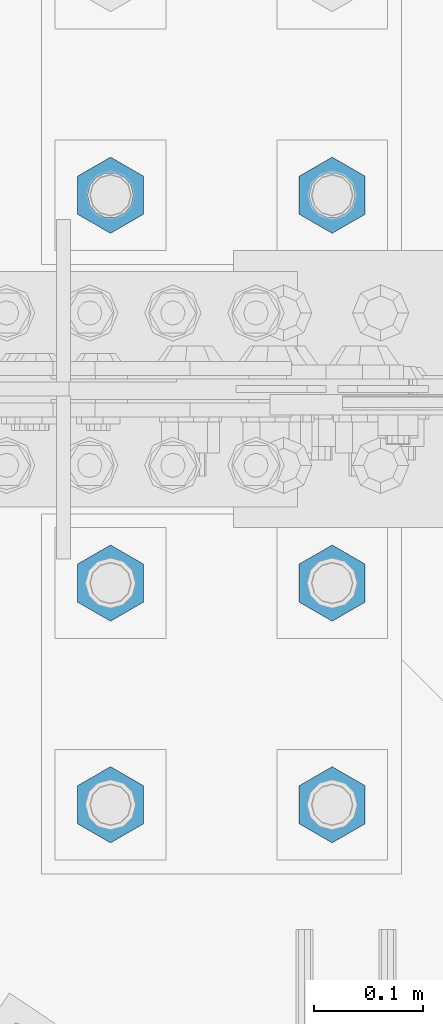
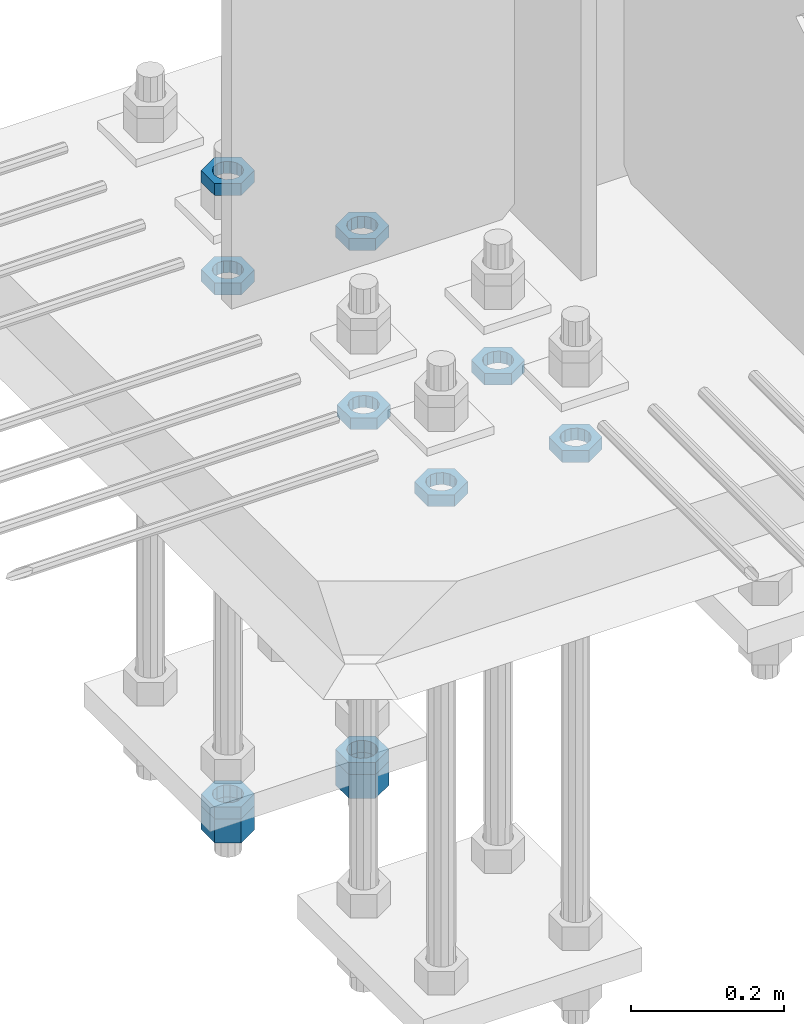
# One storey, part 2961 of 3843: 11 beams, 1 element without a shape of its own.
"""IFC2X3 building model written with IfcOpenShell, lengths in millimetres."""

from ifc_helpers import new_model, si_unit, frame, origin_with_axes, place, context, subcontext, project, spatial, faceted_brep, material, type_object, element, aggregate, save


model = new_model("IFC2X3")

# Units and contexts
model_context = context("Model", 3, precision=1e-05, world=origin_with_axes())
body_context = subcontext(model_context, "Body", "Model", "MODEL_VIEW")
ifc_project = project(units=[si_unit("LENGTHUNIT", "METRE", prefix="MILLI"), si_unit("AREAUNIT", "SQUARE_METRE"), si_unit("VOLUMEUNIT", "CUBIC_METRE"), si_unit("MASSUNIT", "GRAM", prefix="KILO"), si_unit("TIMEUNIT", "SECOND"), si_unit("PLANEANGLEUNIT", "RADIAN"), si_unit("SOLIDANGLEUNIT", "STERADIAN"), si_unit("THERMODYNAMICTEMPERATUREUNIT", "DEGREE_CELSIUS"), si_unit("LUMINOUSINTENSITYUNIT", "LUMEN")], contexts=[model_context])

# Site, building, storey
site_placement = place(None, origin_with_axes())
site = spatial("IfcSite", under=ifc_project, at=site_placement, CompositionType="ELEMENT")
building_placement = place(site_placement, origin_with_axes())
building = spatial("IfcBuilding", under=site, at=building_placement, Name="Undefined", CompositionType="ELEMENT")
storey_placement = place(building_placement, origin_with_axes())
storey = spatial("IfcBuildingStorey", under=building, at=storey_placement, Name="Undefined", CompositionType="ELEMENT", Elevation=0.0)

# Assembly, beams
assembly_placement = place(storey_placement, origin_with_axes())
assembly = element("IfcElementAssembly", 1, at=assembly_placement, inside=storey, Name="TEMPLATE", AssemblyPlace="NOTDEFINED", PredefinedType="RIGID_FRAME")
ifc_material = material(Name="STEEL/A572-50")
beam_type_1 = type_object("IfcBeamType", Name="1-1/2_HEAVY_HEX_NUT", PredefinedType="NOTDEFINED")
beam_1_placement = place(assembly_placement, frame((85140.8, 104736.9, 28746.45), z_axis=(-1.0, 0.0, 0.0), x_axis=(0.0, 0.0, -1.0)))
beam_1 = element("IfcBeam", 2, at=beam_1_placement, type_object=beam_type_1, material=ifc_material, Name="NUT", ObjectType="1-1/2_HEAVY_HEX_NUT", context=body_context, shape_type="Brep", body=[
    faceted_brep([(0.0, -34.9199981689453, 0.0), (0.0, -17.4599990844727, -30.25), (38.0999999999985, -17.4599990844727, -30.25), (38.0999999999985, -34.9199981689453, 0.0), (0.0, 17.4599990844727, -30.25), (38.0999999999985, 17.4599990844727, -30.25), (0.0, 34.9199981689453, 0.0), (38.0999999999985, 34.9199981689453, 0.0), (0.0, 17.4599990844727, 30.25), (38.0999999999985, 17.4599990844727, 30.25), (0.0, -17.4599990844727, 30.25), (38.0999999999985, -17.4599990844727, 30.25), (0.0, 0.0, 20.6399993896484), (0.0, 8.9553601105581, 18.5959968835959), (38.0999999999985, 8.9553601105581, 18.5959968835959), (38.0999999999985, 0.0, 20.6399993896484), (0.0, 16.1370013209525, 12.8688291298167), (38.0999999999985, 16.1370013209525, 12.8688291298167), (0.0, 20.1225115123816, 4.59283194104501), (38.0999999999985, 20.1225115123816, 4.59283194104501), (0.0, 20.1225115123816, -4.59283194104501), (38.0999999999985, 20.1225115123816, -4.59283194104501), (0.0, 16.1370013209525, -12.8688291298167), (38.0999999999985, 16.1370013209525, -12.8688291298167), (0.0, 8.9553601105581, -18.5959968835959), (38.0999999999985, 8.9553601105581, -18.5959968835959), (0.0, 0.0, -20.6399993896484), (38.0999999999985, 0.0, -20.6399993896484), (0.0, -8.9553601105581, -18.5959968835959), (38.0999999999985, -8.9553601105581, -18.5959968835959), (0.0, -16.1370013209525, -12.8688291298167), (38.0999999999985, -16.1370013209525, -12.8688291298167), (0.0, -20.1225115123816, -4.59283194104501), (38.0999999999985, -20.1225115123816, -4.59283194104501), (0.0, -20.1225115123816, 4.59283194104501), (38.0999999999985, -20.1225115123816, 4.59283194104501), (0.0, -16.1370013209525, 12.8688291298167), (38.0999999999985, -16.1370013209525, 12.8688291298167), (0.0, -8.9553601105581, 18.5959968835959), (38.0999999999985, -8.9553601105581, 18.5959968835959)], [[[0, 1, 2, 3]], [[1, 4, 5, 2]], [[4, 6, 7, 5]], [[6, 8, 9, 7]], [[8, 10, 11, 9]], [[10, 0, 3, 11]], [[12, 13, 14, 15]], [[13, 16, 17, 14]], [[16, 18, 19, 17]], [[18, 20, 21, 19]], [[20, 22, 23, 21]], [[22, 24, 25, 23]], [[24, 26, 27, 25]], [[26, 28, 29, 27]], [[28, 30, 31, 29]], [[30, 32, 33, 31]], [[32, 34, 35, 33]], [[34, 36, 37, 35]], [[36, 38, 39, 37]], [[38, 12, 15, 39]], [[5, 7, 9, 11, 3, 2], [17, 19, 21, 23, 25, 27, 29, 31, 33, 35, 37, 39, 15, 14]], [[10, 8, 6, 4, 1, 0], [38, 36, 34, 32, 30, 28, 26, 24, 22, 20, 18, 16, 13, 12]]]),
])
beam_2_placement = place(assembly_placement, frame((85344.0, 104736.9, 28746.45), z_axis=(-1.0, 0.0, 0.0), x_axis=(0.0, 0.0, -1.0)))
beam_2 = element("IfcBeam", 3, at=beam_2_placement, type_object=beam_type_1, material=ifc_material, Name="NUT", ObjectType="1-1/2_HEAVY_HEX_NUT", context=body_context, shape_type="Brep", body=[
    faceted_brep([(0.0, -34.9199981689453, 0.0), (0.0, -17.4599990844727, -30.25), (38.0999999999985, -17.4599990844727, -30.25), (38.0999999999985, -34.9199981689453, 0.0), (0.0, 17.4599990844727, -30.25), (38.0999999999985, 17.4599990844727, -30.25), (0.0, 34.9199981689453, 0.0), (38.0999999999985, 34.9199981689453, 0.0), (0.0, 17.4599990844727, 30.25), (38.0999999999985, 17.4599990844727, 30.25), (0.0, -17.4599990844727, 30.25), (38.0999999999985, -17.4599990844727, 30.25), (0.0, 0.0, 20.6399993896484), (0.0, 8.9553601105581, 18.5959968835959), (38.0999999999985, 8.9553601105581, 18.5959968835959), (38.0999999999985, 0.0, 20.6399993896484), (0.0, 16.1370013209525, 12.8688291298167), (38.0999999999985, 16.1370013209525, 12.8688291298167), (0.0, 20.1225115123816, 4.59283194104501), (38.0999999999985, 20.1225115123816, 4.59283194104501), (0.0, 20.1225115123816, -4.59283194104501), (38.0999999999985, 20.1225115123816, -4.59283194104501), (0.0, 16.1370013209525, -12.8688291298167), (38.0999999999985, 16.1370013209525, -12.8688291298167), (0.0, 8.9553601105581, -18.5959968835959), (38.0999999999985, 8.9553601105581, -18.5959968835959), (0.0, 0.0, -20.6399993896484), (38.0999999999985, 0.0, -20.6399993896484), (0.0, -8.9553601105581, -18.5959968835959), (38.0999999999985, -8.9553601105581, -18.5959968835959), (0.0, -16.1370013209525, -12.8688291298167), (38.0999999999985, -16.1370013209525, -12.8688291298167), (0.0, -20.1225115123816, -4.59283194104501), (38.0999999999985, -20.1225115123816, -4.59283194104501), (0.0, -20.1225115123816, 4.59283194104501), (38.0999999999985, -20.1225115123816, 4.59283194104501), (0.0, -16.1370013209525, 12.8688291298167), (38.0999999999985, -16.1370013209525, 12.8688291298167), (0.0, -8.9553601105581, 18.5959968835959), (38.0999999999985, -8.9553601105581, 18.5959968835959)], [[[0, 1, 2, 3]], [[1, 4, 5, 2]], [[4, 6, 7, 5]], [[6, 8, 9, 7]], [[8, 10, 11, 9]], [[10, 0, 3, 11]], [[12, 13, 14, 15]], [[13, 16, 17, 14]], [[16, 18, 19, 17]], [[18, 20, 21, 19]], [[20, 22, 23, 21]], [[22, 24, 25, 23]], [[24, 26, 27, 25]], [[26, 28, 29, 27]], [[28, 30, 31, 29]], [[30, 32, 33, 31]], [[32, 34, 35, 33]], [[34, 36, 37, 35]], [[36, 38, 39, 37]], [[38, 12, 15, 39]], [[5, 7, 9, 11, 3, 2], [17, 19, 21, 23, 25, 27, 29, 31, 33, 35, 37, 39, 15, 14]], [[10, 8, 6, 4, 1, 0], [38, 36, 34, 32, 30, 28, 26, 24, 22, 20, 18, 16, 13, 12]]]),
])
beam_type_2 = type_object("IfcBeamType", Name="1-1/2_HALF_NUT", PredefinedType="NOTDEFINED")
beam_3_placement = place(assembly_placement, frame((85140.8, 104736.9, 29603.7), z_axis=(-1.0, 0.0, 0.0), x_axis=(0.0, 0.0, -1.0)))
beam_3 = element("IfcBeam", 4, at=beam_3_placement, type_object=beam_type_2, material=ifc_material, Name="NUT", ObjectType="1-1/2_HALF_NUT", context=body_context, shape_type="Brep", body=[
    faceted_brep([(0.0, -34.9199981689453, 0.0), (0.0, -17.4599990844727, -30.25), (19.0500000000029, -17.4599990844727, -30.25), (19.0500000000029, -34.9199981689453, 0.0), (0.0, 17.4599990844727, -30.25), (19.0500000000029, 17.4599990844727, -30.25), (0.0, 34.9199981689453, 0.0), (19.0500000000029, 34.9199981689453, 0.0), (0.0, 17.4599990844727, 30.25), (19.0500000000029, 17.4599990844727, 30.25), (0.0, -17.4599990844727, 30.25), (19.0500000000029, -17.4599990844727, 30.25), (0.0, 0.0, 20.6399993896484), (0.0, 8.9553601105581, 18.5959968835959), (19.0500000000029, 8.95536011056538, 18.5959968835959), (19.0500000000029, 0.0, 20.6399993896484), (0.0, 16.1370013209525, 12.8688291298167), (19.0500000000029, 16.1370013209489, 12.8688291298167), (0.0, 20.1225115123816, 4.59283194104501), (19.0500000000029, 20.1225115123852, 4.59283194104501), (0.0, 20.1225115123816, -4.59283194104501), (19.0500000000029, 20.1225115123852, -4.59283194104501), (0.0, 16.1370013209525, -12.8688291298167), (19.0500000000029, 16.1370013209489, -12.8688291298167), (0.0, 8.9553601105581, -18.5959968835959), (19.0500000000029, 8.95536011056538, -18.5959968835959), (0.0, 0.0, -20.6399993896484), (19.0500000000029, 0.0, -20.6399993896484), (0.0, -8.9553601105581, -18.5959968835959), (19.0500000000029, -8.95536011056538, -18.5959968835959), (0.0, -16.1370013209525, -12.8688291298167), (19.0500000000029, -16.1370013209489, -12.8688291298167), (0.0, -20.1225115123816, -4.59283194104501), (19.0500000000029, -20.1225115123852, -4.59283194104501), (0.0, -20.1225115123816, 4.59283194104501), (19.0500000000029, -20.1225115123852, 4.59283194104501), (0.0, -16.1370013209525, 12.8688291298167), (19.0500000000029, -16.1370013209489, 12.8688291298167), (0.0, -8.9553601105581, 18.5959968835959), (19.0500000000029, -8.95536011056538, 18.5959968835959)], [[[0, 1, 2, 3]], [[1, 4, 5, 2]], [[4, 6, 7, 5]], [[6, 8, 9, 7]], [[8, 10, 11, 9]], [[10, 0, 3, 11]], [[12, 13, 14, 15]], [[13, 16, 17, 14]], [[16, 18, 19, 17]], [[18, 20, 21, 19]], [[20, 22, 23, 21]], [[22, 24, 25, 23]], [[24, 26, 27, 25]], [[26, 28, 29, 27]], [[28, 30, 31, 29]], [[30, 32, 33, 31]], [[32, 34, 35, 33]], [[34, 36, 37, 35]], [[36, 38, 39, 37]], [[38, 12, 15, 39]], [[5, 7, 9, 11, 3, 2], [17, 19, 21, 23, 25, 27, 29, 31, 33, 35, 37, 39, 15, 14]], [[10, 8, 6, 4, 1, 0], [38, 36, 34, 32, 30, 28, 26, 24, 22, 20, 18, 16, 13, 12]]]),
])
beam_4_placement = place(assembly_placement, frame((85344.0, 104736.9, 29603.7), z_axis=(-1.0, 0.0, 0.0), x_axis=(0.0, 0.0, -1.0)))
beam_4 = element("IfcBeam", 5, at=beam_4_placement, type_object=beam_type_2, material=ifc_material, Name="NUT", ObjectType="1-1/2_HALF_NUT", context=body_context, shape_type="Brep", body=[
    faceted_brep([(0.0, -34.9199981689453, 0.0), (0.0, -17.4599990844727, -30.25), (19.0500000000029, -17.4599990844727, -30.25), (19.0500000000029, -34.9199981689453, 0.0), (0.0, 17.4599990844727, -30.25), (19.0500000000029, 17.4599990844727, -30.25), (0.0, 34.9199981689453, 0.0), (19.0500000000029, 34.9199981689453, 0.0), (0.0, 17.4599990844727, 30.25), (19.0500000000029, 17.4599990844727, 30.25), (0.0, -17.4599990844727, 30.25), (19.0500000000029, -17.4599990844727, 30.25), (0.0, 0.0, 20.6399993896484), (0.0, 8.9553601105581, 18.5959968835959), (19.0500000000029, 8.95536011056538, 18.5959968835959), (19.0500000000029, 0.0, 20.6399993896484), (0.0, 16.1370013209525, 12.8688291298167), (19.0500000000029, 16.1370013209489, 12.8688291298167), (0.0, 20.1225115123816, 4.59283194104501), (19.0500000000029, 20.1225115123852, 4.59283194104501), (0.0, 20.1225115123816, -4.59283194104501), (19.0500000000029, 20.1225115123852, -4.59283194104501), (0.0, 16.1370013209525, -12.8688291298167), (19.0500000000029, 16.1370013209489, -12.8688291298167), (0.0, 8.9553601105581, -18.5959968835959), (19.0500000000029, 8.95536011056538, -18.5959968835959), (0.0, 0.0, -20.6399993896484), (19.0500000000029, 0.0, -20.6399993896484), (0.0, -8.9553601105581, -18.5959968835959), (19.0500000000029, -8.95536011056538, -18.5959968835959), (0.0, -16.1370013209525, -12.8688291298167), (19.0500000000029, -16.1370013209489, -12.8688291298167), (0.0, -20.1225115123816, -4.59283194104501), (19.0500000000029, -20.1225115123852, -4.59283194104501), (0.0, -20.1225115123816, 4.59283194104501), (19.0500000000029, -20.1225115123852, 4.59283194104501), (0.0, -16.1370013209525, 12.8688291298167), (19.0500000000029, -16.1370013209489, 12.8688291298167), (0.0, -8.9553601105581, 18.5959968835959), (19.0500000000029, -8.95536011056538, 18.5959968835959)], [[[0, 1, 2, 3]], [[1, 4, 5, 2]], [[4, 6, 7, 5]], [[6, 8, 9, 7]], [[8, 10, 11, 9]], [[10, 0, 3, 11]], [[12, 13, 14, 15]], [[13, 16, 17, 14]], [[16, 18, 19, 17]], [[18, 20, 21, 19]], [[20, 22, 23, 21]], [[22, 24, 25, 23]], [[24, 26, 27, 25]], [[26, 28, 29, 27]], [[28, 30, 31, 29]], [[30, 32, 33, 31]], [[32, 34, 35, 33]], [[34, 36, 37, 35]], [[36, 38, 39, 37]], [[38, 12, 15, 39]], [[5, 7, 9, 11, 3, 2], [17, 19, 21, 23, 25, 27, 29, 31, 33, 35, 37, 39, 15, 14]], [[10, 8, 6, 4, 1, 0], [38, 36, 34, 32, 30, 28, 26, 24, 22, 20, 18, 16, 13, 12]]]),
])
beam_5_placement = place(assembly_placement, frame((85140.8, 104178.1, 29603.7), z_axis=(1.0, 0.0, 0.0), x_axis=(0.0, 0.0, -1.0)))
beam_5 = element("IfcBeam", 6, at=beam_5_placement, type_object=beam_type_2, material=ifc_material, Name="NUT", ObjectType="1-1/2_HALF_NUT", context=body_context, shape_type="Brep", body=[
    faceted_brep([(0.0, -34.9199981689453, 0.0), (0.0, -17.4599990844727, -30.25), (19.0500000000029, -17.4599990844727, -30.25), (19.0500000000029, -34.9199981689453, 0.0), (0.0, 17.4599990844727, -30.25), (19.0500000000029, 17.4599990844727, -30.25), (0.0, 34.9199981689453, 0.0), (19.0500000000029, 34.9199981689453, 0.0), (0.0, 17.4599990844727, 30.25), (19.0500000000029, 17.4599990844727, 30.25), (0.0, -17.4599990844727, 30.25), (19.0500000000029, -17.4599990844727, 30.25), (0.0, 0.0, 20.6399993896484), (0.0, 8.9553601105581, 18.5959968835959), (19.0500000000029, 8.95536011056538, 18.5959968835959), (19.0500000000029, 0.0, 20.6399993896484), (0.0, 16.1370013209525, 12.8688291298167), (19.0500000000029, 16.1370013209489, 12.8688291298167), (0.0, 20.1225115123816, 4.59283194104501), (19.0500000000029, 20.1225115123852, 4.59283194104501), (0.0, 20.1225115123816, -4.59283194104501), (19.0500000000029, 20.1225115123852, -4.59283194104501), (0.0, 16.1370013209525, -12.8688291298167), (19.0500000000029, 16.1370013209489, -12.8688291298167), (0.0, 8.9553601105581, -18.5959968835959), (19.0500000000029, 8.95536011056538, -18.5959968835959), (0.0, 0.0, -20.6399993896484), (19.0500000000029, 0.0, -20.6399993896484), (0.0, -8.9553601105581, -18.5959968835959), (19.0500000000029, -8.95536011056538, -18.5959968835959), (0.0, -16.1370013209525, -12.8688291298167), (19.0500000000029, -16.1370013209489, -12.8688291298167), (0.0, -20.1225115123816, -4.59283194104501), (19.0500000000029, -20.1225115123852, -4.59283194104501), (0.0, -20.1225115123816, 4.59283194104501), (19.0500000000029, -20.1225115123852, 4.59283194104501), (0.0, -16.1370013209525, 12.8688291298167), (19.0500000000029, -16.1370013209489, 12.8688291298167), (0.0, -8.9553601105581, 18.5959968835959), (19.0500000000029, -8.95536011056538, 18.5959968835959)], [[[0, 1, 2, 3]], [[1, 4, 5, 2]], [[4, 6, 7, 5]], [[6, 8, 9, 7]], [[8, 10, 11, 9]], [[10, 0, 3, 11]], [[12, 13, 14, 15]], [[13, 16, 17, 14]], [[16, 18, 19, 17]], [[18, 20, 21, 19]], [[20, 22, 23, 21]], [[22, 24, 25, 23]], [[24, 26, 27, 25]], [[26, 28, 29, 27]], [[28, 30, 31, 29]], [[30, 32, 33, 31]], [[32, 34, 35, 33]], [[34, 36, 37, 35]], [[36, 38, 39, 37]], [[38, 12, 15, 39]], [[5, 7, 9, 11, 3, 2], [17, 19, 21, 23, 25, 27, 29, 31, 33, 35, 37, 39, 15, 14]], [[10, 8, 6, 4, 1, 0], [38, 36, 34, 32, 30, 28, 26, 24, 22, 20, 18, 16, 13, 12]]]),
])
beam_6_placement = place(assembly_placement, frame((85140.8, 104381.3, 29603.7), z_axis=(1.0, 0.0, 0.0), x_axis=(0.0, 0.0, -1.0)))
beam_6 = element("IfcBeam", 7, at=beam_6_placement, type_object=beam_type_2, material=ifc_material, Name="NUT", ObjectType="1-1/2_HALF_NUT", context=body_context, shape_type="Brep", body=[
    faceted_brep([(0.0, -34.9199981689453, 0.0), (0.0, -17.4599990844727, -30.25), (19.0500000000029, -17.4599990844727, -30.25), (19.0500000000029, -34.9199981689453, 0.0), (0.0, 17.4599990844727, -30.25), (19.0500000000029, 17.4599990844727, -30.25), (0.0, 34.9199981689453, 0.0), (19.0500000000029, 34.9199981689453, 0.0), (0.0, 17.4599990844727, 30.25), (19.0500000000029, 17.4599990844727, 30.25), (0.0, -17.4599990844727, 30.25), (19.0500000000029, -17.4599990844727, 30.25), (0.0, 0.0, 20.6399993896484), (0.0, 8.9553601105581, 18.5959968835959), (19.0500000000029, 8.95536011056538, 18.5959968835959), (19.0500000000029, 0.0, 20.6399993896484), (0.0, 16.1370013209525, 12.8688291298167), (19.0500000000029, 16.1370013209489, 12.8688291298167), (0.0, 20.1225115123816, 4.59283194104501), (19.0500000000029, 20.1225115123852, 4.59283194104501), (0.0, 20.1225115123816, -4.59283194104501), (19.0500000000029, 20.1225115123852, -4.59283194104501), (0.0, 16.1370013209525, -12.8688291298167), (19.0500000000029, 16.1370013209489, -12.8688291298167), (0.0, 8.9553601105581, -18.5959968835959), (19.0500000000029, 8.95536011056538, -18.5959968835959), (0.0, 0.0, -20.6399993896484), (19.0500000000029, 0.0, -20.6399993896484), (0.0, -8.9553601105581, -18.5959968835959), (19.0500000000029, -8.95536011056538, -18.5959968835959), (0.0, -16.1370013209525, -12.8688291298167), (19.0500000000029, -16.1370013209489, -12.8688291298167), (0.0, -20.1225115123816, -4.59283194104501), (19.0500000000029, -20.1225115123852, -4.59283194104501), (0.0, -20.1225115123816, 4.59283194104501), (19.0500000000029, -20.1225115123852, 4.59283194104501), (0.0, -16.1370013209525, 12.8688291298167), (19.0500000000029, -16.1370013209489, 12.8688291298167), (0.0, -8.9553601105581, 18.5959968835959), (19.0500000000029, -8.95536011056538, 18.5959968835959)], [[[0, 1, 2, 3]], [[1, 4, 5, 2]], [[4, 6, 7, 5]], [[6, 8, 9, 7]], [[8, 10, 11, 9]], [[10, 0, 3, 11]], [[12, 13, 14, 15]], [[13, 16, 17, 14]], [[16, 18, 19, 17]], [[18, 20, 21, 19]], [[20, 22, 23, 21]], [[22, 24, 25, 23]], [[24, 26, 27, 25]], [[26, 28, 29, 27]], [[28, 30, 31, 29]], [[30, 32, 33, 31]], [[32, 34, 35, 33]], [[34, 36, 37, 35]], [[36, 38, 39, 37]], [[38, 12, 15, 39]], [[5, 7, 9, 11, 3, 2], [17, 19, 21, 23, 25, 27, 29, 31, 33, 35, 37, 39, 15, 14]], [[10, 8, 6, 4, 1, 0], [38, 36, 34, 32, 30, 28, 26, 24, 22, 20, 18, 16, 13, 12]]]),
])
beam_7_placement = place(assembly_placement, frame((85344.0, 104381.3, 29603.7), z_axis=(1.0, 0.0, 0.0), x_axis=(0.0, 0.0, -1.0)))
beam_7 = element("IfcBeam", 8, at=beam_7_placement, type_object=beam_type_2, material=ifc_material, Name="NUT", ObjectType="1-1/2_HALF_NUT", context=body_context, shape_type="Brep", body=[
    faceted_brep([(0.0, -34.9199981689453, 0.0), (0.0, -17.4599990844727, -30.25), (19.0500000000029, -17.4599990844727, -30.25), (19.0500000000029, -34.9199981689453, 0.0), (0.0, 17.4599990844727, -30.25), (19.0500000000029, 17.4599990844727, -30.25), (0.0, 34.9199981689453, 0.0), (19.0500000000029, 34.9199981689453, 0.0), (0.0, 17.4599990844727, 30.25), (19.0500000000029, 17.4599990844727, 30.25), (0.0, -17.4599990844727, 30.25), (19.0500000000029, -17.4599990844727, 30.25), (0.0, 0.0, 20.6399993896484), (0.0, 8.9553601105581, 18.5959968835959), (19.0500000000029, 8.95536011056538, 18.5959968835959), (19.0500000000029, 0.0, 20.6399993896484), (0.0, 16.1370013209525, 12.8688291298167), (19.0500000000029, 16.1370013209489, 12.8688291298167), (0.0, 20.1225115123816, 4.59283194104501), (19.0500000000029, 20.1225115123852, 4.59283194104501), (0.0, 20.1225115123816, -4.59283194104501), (19.0500000000029, 20.1225115123852, -4.59283194104501), (0.0, 16.1370013209525, -12.8688291298167), (19.0500000000029, 16.1370013209489, -12.8688291298167), (0.0, 8.9553601105581, -18.5959968835959), (19.0500000000029, 8.95536011056538, -18.5959968835959), (0.0, 0.0, -20.6399993896484), (19.0500000000029, 0.0, -20.6399993896484), (0.0, -8.9553601105581, -18.5959968835959), (19.0500000000029, -8.95536011056538, -18.5959968835959), (0.0, -16.1370013209525, -12.8688291298167), (19.0500000000029, -16.1370013209489, -12.8688291298167), (0.0, -20.1225115123816, -4.59283194104501), (19.0500000000029, -20.1225115123852, -4.59283194104501), (0.0, -20.1225115123816, 4.59283194104501), (19.0500000000029, -20.1225115123852, 4.59283194104501), (0.0, -16.1370013209525, 12.8688291298167), (19.0500000000029, -16.1370013209489, 12.8688291298167), (0.0, -8.9553601105581, 18.5959968835959), (19.0500000000029, -8.95536011056538, 18.5959968835959)], [[[0, 1, 2, 3]], [[1, 4, 5, 2]], [[4, 6, 7, 5]], [[6, 8, 9, 7]], [[8, 10, 11, 9]], [[10, 0, 3, 11]], [[12, 13, 14, 15]], [[13, 16, 17, 14]], [[16, 18, 19, 17]], [[18, 20, 21, 19]], [[20, 22, 23, 21]], [[22, 24, 25, 23]], [[24, 26, 27, 25]], [[26, 28, 29, 27]], [[28, 30, 31, 29]], [[30, 32, 33, 31]], [[32, 34, 35, 33]], [[34, 36, 37, 35]], [[36, 38, 39, 37]], [[38, 12, 15, 39]], [[5, 7, 9, 11, 3, 2], [17, 19, 21, 23, 25, 27, 29, 31, 33, 35, 37, 39, 15, 14]], [[10, 8, 6, 4, 1, 0], [38, 36, 34, 32, 30, 28, 26, 24, 22, 20, 18, 16, 13, 12]]]),
])
beam_8_placement = place(assembly_placement, frame((85344.0, 104178.1, 29603.7), z_axis=(1.0, 0.0, 0.0), x_axis=(0.0, 0.0, -1.0)))
beam_8 = element("IfcBeam", 9, at=beam_8_placement, type_object=beam_type_2, material=ifc_material, Name="NUT", ObjectType="1-1/2_HALF_NUT", context=body_context, shape_type="Brep", body=[
    faceted_brep([(0.0, -34.9199981689453, 0.0), (0.0, -17.4599990844727, -30.25), (19.0500000000029, -17.4599990844727, -30.25), (19.0500000000029, -34.9199981689453, 0.0), (0.0, 17.4599990844727, -30.25), (19.0500000000029, 17.4599990844727, -30.25), (0.0, 34.9199981689453, 0.0), (19.0500000000029, 34.9199981689453, 0.0), (0.0, 17.4599990844727, 30.25), (19.0500000000029, 17.4599990844727, 30.25), (0.0, -17.4599990844727, 30.25), (19.0500000000029, -17.4599990844727, 30.25), (0.0, 0.0, 20.6399993896484), (0.0, 8.9553601105581, 18.5959968835959), (19.0500000000029, 8.95536011056538, 18.5959968835959), (19.0500000000029, 0.0, 20.6399993896484), (0.0, 16.1370013209525, 12.8688291298167), (19.0500000000029, 16.1370013209489, 12.8688291298167), (0.0, 20.1225115123816, 4.59283194104501), (19.0500000000029, 20.1225115123852, 4.59283194104501), (0.0, 20.1225115123816, -4.59283194104501), (19.0500000000029, 20.1225115123852, -4.59283194104501), (0.0, 16.1370013209525, -12.8688291298167), (19.0500000000029, 16.1370013209489, -12.8688291298167), (0.0, 8.9553601105581, -18.5959968835959), (19.0500000000029, 8.95536011056538, -18.5959968835959), (0.0, 0.0, -20.6399993896484), (19.0500000000029, 0.0, -20.6399993896484), (0.0, -8.9553601105581, -18.5959968835959), (19.0500000000029, -8.95536011056538, -18.5959968835959), (0.0, -16.1370013209525, -12.8688291298167), (19.0500000000029, -16.1370013209489, -12.8688291298167), (0.0, -20.1225115123816, -4.59283194104501), (19.0500000000029, -20.1225115123852, -4.59283194104501), (0.0, -20.1225115123816, 4.59283194104501), (19.0500000000029, -20.1225115123852, 4.59283194104501), (0.0, -16.1370013209525, 12.8688291298167), (19.0500000000029, -16.1370013209489, 12.8688291298167), (0.0, -8.9553601105581, 18.5959968835959), (19.0500000000029, -8.95536011056538, 18.5959968835959)], [[[0, 1, 2, 3]], [[1, 4, 5, 2]], [[4, 6, 7, 5]], [[6, 8, 9, 7]], [[8, 10, 11, 9]], [[10, 0, 3, 11]], [[12, 13, 14, 15]], [[13, 16, 17, 14]], [[16, 18, 19, 17]], [[18, 20, 21, 19]], [[20, 22, 23, 21]], [[22, 24, 25, 23]], [[24, 26, 27, 25]], [[26, 28, 29, 27]], [[28, 30, 31, 29]], [[30, 32, 33, 31]], [[32, 34, 35, 33]], [[34, 36, 37, 35]], [[36, 38, 39, 37]], [[38, 12, 15, 39]], [[5, 7, 9, 11, 3, 2], [17, 19, 21, 23, 25, 27, 29, 31, 33, 35, 37, 39, 15, 14]], [[10, 8, 6, 4, 1, 0], [38, 36, 34, 32, 30, 28, 26, 24, 22, 20, 18, 16, 13, 12]]]),
])
beam_9_placement = place(assembly_placement, frame((85140.8, 104736.9, 28765.5), z_axis=(-1.0, 0.0, 0.0), x_axis=(0.0, 0.0, -1.0)))
beam_9 = element("IfcBeam", 10, at=beam_9_placement, type_object=beam_type_2, material=ifc_material, Name="NUT", ObjectType="1-1/2_HALF_NUT", context=body_context, shape_type="Brep", body=[
    faceted_brep([(0.0, -34.9199981689453, 0.0), (0.0, -17.4599990844727, -30.25), (19.0500000000029, -17.4599990844727, -30.25), (19.0500000000029, -34.9199981689453, 0.0), (0.0, 17.4599990844727, -30.25), (19.0500000000029, 17.4599990844727, -30.25), (0.0, 34.9199981689453, 0.0), (19.0500000000029, 34.9199981689453, 0.0), (0.0, 17.4599990844727, 30.25), (19.0500000000029, 17.4599990844727, 30.25), (0.0, -17.4599990844727, 30.25), (19.0500000000029, -17.4599990844727, 30.25), (0.0, 0.0, 20.6399993896484), (0.0, 8.9553601105581, 18.5959968835959), (19.0500000000029, 8.95536011056538, 18.5959968835959), (19.0500000000029, 0.0, 20.6399993896484), (0.0, 16.1370013209525, 12.8688291298167), (19.0500000000029, 16.1370013209489, 12.8688291298167), (0.0, 20.1225115123816, 4.59283194104501), (19.0500000000029, 20.1225115123852, 4.59283194104501), (0.0, 20.1225115123816, -4.59283194104501), (19.0500000000029, 20.1225115123852, -4.59283194104501), (0.0, 16.1370013209525, -12.8688291298167), (19.0500000000029, 16.1370013209489, -12.8688291298167), (0.0, 8.9553601105581, -18.5959968835959), (19.0500000000029, 8.95536011056538, -18.5959968835959), (0.0, 0.0, -20.6399993896484), (19.0500000000029, 0.0, -20.6399993896484), (0.0, -8.9553601105581, -18.5959968835959), (19.0500000000029, -8.95536011056538, -18.5959968835959), (0.0, -16.1370013209525, -12.8688291298167), (19.0500000000029, -16.1370013209489, -12.8688291298167), (0.0, -20.1225115123816, -4.59283194104501), (19.0500000000029, -20.1225115123852, -4.59283194104501), (0.0, -20.1225115123816, 4.59283194104501), (19.0500000000029, -20.1225115123852, 4.59283194104501), (0.0, -16.1370013209525, 12.8688291298167), (19.0500000000029, -16.1370013209489, 12.8688291298167), (0.0, -8.9553601105581, 18.5959968835959), (19.0500000000029, -8.95536011056538, 18.5959968835959)], [[[0, 1, 2, 3]], [[1, 4, 5, 2]], [[4, 6, 7, 5]], [[6, 8, 9, 7]], [[8, 10, 11, 9]], [[10, 0, 3, 11]], [[12, 13, 14, 15]], [[13, 16, 17, 14]], [[16, 18, 19, 17]], [[18, 20, 21, 19]], [[20, 22, 23, 21]], [[22, 24, 25, 23]], [[24, 26, 27, 25]], [[26, 28, 29, 27]], [[28, 30, 31, 29]], [[30, 32, 33, 31]], [[32, 34, 35, 33]], [[34, 36, 37, 35]], [[36, 38, 39, 37]], [[38, 12, 15, 39]], [[5, 7, 9, 11, 3, 2], [17, 19, 21, 23, 25, 27, 29, 31, 33, 35, 37, 39, 15, 14]], [[10, 8, 6, 4, 1, 0], [38, 36, 34, 32, 30, 28, 26, 24, 22, 20, 18, 16, 13, 12]]]),
])
beam_10_placement = place(assembly_placement, frame((85140.8, 104736.9, 29762.45), z_axis=(-1.0, 0.0, 0.0), x_axis=(0.0, 0.0, -1.0)))
beam_10 = element("IfcBeam", 11, at=beam_10_placement, type_object=beam_type_2, material=ifc_material, Name="NUT", ObjectType="1-1/2_HALF_NUT", context=body_context, shape_type="Brep", body=[
    faceted_brep([(0.0, -34.9199981689453, 0.0), (0.0, -17.4599990844727, -30.25), (19.0500000000029, -17.4599990844727, -30.25), (19.0500000000029, -34.9199981689453, 0.0), (0.0, 17.4599990844727, -30.25), (19.0500000000029, 17.4599990844727, -30.25), (0.0, 34.9199981689453, 0.0), (19.0500000000029, 34.9199981689453, 0.0), (0.0, 17.4599990844727, 30.25), (19.0500000000029, 17.4599990844727, 30.25), (0.0, -17.4599990844727, 30.25), (19.0500000000029, -17.4599990844727, 30.25), (0.0, 0.0, 20.6399993896484), (0.0, 8.9553601105581, 18.5959968835959), (19.0500000000029, 8.95536011056538, 18.5959968835959), (19.0500000000029, 0.0, 20.6399993896484), (0.0, 16.1370013209525, 12.8688291298167), (19.0500000000029, 16.1370013209489, 12.8688291298167), (0.0, 20.1225115123816, 4.59283194104501), (19.0500000000029, 20.1225115123852, 4.59283194104501), (0.0, 20.1225115123816, -4.59283194104501), (19.0500000000029, 20.1225115123852, -4.59283194104501), (0.0, 16.1370013209525, -12.8688291298167), (19.0500000000029, 16.1370013209489, -12.8688291298167), (0.0, 8.9553601105581, -18.5959968835959), (19.0500000000029, 8.95536011056538, -18.5959968835959), (0.0, 0.0, -20.6399993896484), (19.0500000000029, 0.0, -20.6399993896484), (0.0, -8.9553601105581, -18.5959968835959), (19.0500000000029, -8.95536011056538, -18.5959968835959), (0.0, -16.1370013209525, -12.8688291298167), (19.0500000000029, -16.1370013209489, -12.8688291298167), (0.0, -20.1225115123816, -4.59283194104501), (19.0500000000029, -20.1225115123852, -4.59283194104501), (0.0, -20.1225115123816, 4.59283194104501), (19.0500000000029, -20.1225115123852, 4.59283194104501), (0.0, -16.1370013209525, 12.8688291298167), (19.0500000000029, -16.1370013209489, 12.8688291298167), (0.0, -8.9553601105581, 18.5959968835959), (19.0500000000029, -8.95536011056538, 18.5959968835959)], [[[0, 1, 2, 3]], [[1, 4, 5, 2]], [[4, 6, 7, 5]], [[6, 8, 9, 7]], [[8, 10, 11, 9]], [[10, 0, 3, 11]], [[12, 13, 14, 15]], [[13, 16, 17, 14]], [[16, 18, 19, 17]], [[18, 20, 21, 19]], [[20, 22, 23, 21]], [[22, 24, 25, 23]], [[24, 26, 27, 25]], [[26, 28, 29, 27]], [[28, 30, 31, 29]], [[30, 32, 33, 31]], [[32, 34, 35, 33]], [[34, 36, 37, 35]], [[36, 38, 39, 37]], [[38, 12, 15, 39]], [[5, 7, 9, 11, 3, 2], [17, 19, 21, 23, 25, 27, 29, 31, 33, 35, 37, 39, 15, 14]], [[10, 8, 6, 4, 1, 0], [38, 36, 34, 32, 30, 28, 26, 24, 22, 20, 18, 16, 13, 12]]]),
])
beam_11_placement = place(assembly_placement, frame((85344.0, 104736.9, 28765.5), z_axis=(-1.0, 0.0, 0.0), x_axis=(0.0, 0.0, -1.0)))
beam_11 = element("IfcBeam", 12, at=beam_11_placement, type_object=beam_type_2, material=ifc_material, Name="NUT", ObjectType="1-1/2_HALF_NUT", context=body_context, shape_type="Brep", body=[
    faceted_brep([(0.0, -34.9199981689453, 0.0), (0.0, -17.4599990844727, -30.25), (19.0500000000029, -17.4599990844727, -30.25), (19.0500000000029, -34.9199981689453, 0.0), (0.0, 17.4599990844727, -30.25), (19.0500000000029, 17.4599990844727, -30.25), (0.0, 34.9199981689453, 0.0), (19.0500000000029, 34.9199981689453, 0.0), (0.0, 17.4599990844727, 30.25), (19.0500000000029, 17.4599990844727, 30.25), (0.0, -17.4599990844727, 30.25), (19.0500000000029, -17.4599990844727, 30.25), (0.0, 0.0, 20.6399993896484), (0.0, 8.9553601105581, 18.5959968835959), (19.0500000000029, 8.95536011056538, 18.5959968835959), (19.0500000000029, 0.0, 20.6399993896484), (0.0, 16.1370013209525, 12.8688291298167), (19.0500000000029, 16.1370013209489, 12.8688291298167), (0.0, 20.1225115123816, 4.59283194104501), (19.0500000000029, 20.1225115123852, 4.59283194104501), (0.0, 20.1225115123816, -4.59283194104501), (19.0500000000029, 20.1225115123852, -4.59283194104501), (0.0, 16.1370013209525, -12.8688291298167), (19.0500000000029, 16.1370013209489, -12.8688291298167), (0.0, 8.9553601105581, -18.5959968835959), (19.0500000000029, 8.95536011056538, -18.5959968835959), (0.0, 0.0, -20.6399993896484), (19.0500000000029, 0.0, -20.6399993896484), (0.0, -8.9553601105581, -18.5959968835959), (19.0500000000029, -8.95536011056538, -18.5959968835959), (0.0, -16.1370013209525, -12.8688291298167), (19.0500000000029, -16.1370013209489, -12.8688291298167), (0.0, -20.1225115123816, -4.59283194104501), (19.0500000000029, -20.1225115123852, -4.59283194104501), (0.0, -20.1225115123816, 4.59283194104501), (19.0500000000029, -20.1225115123852, 4.59283194104501), (0.0, -16.1370013209525, 12.8688291298167), (19.0500000000029, -16.1370013209489, 12.8688291298167), (0.0, -8.9553601105581, 18.5959968835959), (19.0500000000029, -8.95536011056538, 18.5959968835959)], [[[0, 1, 2, 3]], [[1, 4, 5, 2]], [[4, 6, 7, 5]], [[6, 8, 9, 7]], [[8, 10, 11, 9]], [[10, 0, 3, 11]], [[12, 13, 14, 15]], [[13, 16, 17, 14]], [[16, 18, 19, 17]], [[18, 20, 21, 19]], [[20, 22, 23, 21]], [[22, 24, 25, 23]], [[24, 26, 27, 25]], [[26, 28, 29, 27]], [[28, 30, 31, 29]], [[30, 32, 33, 31]], [[32, 34, 35, 33]], [[34, 36, 37, 35]], [[36, 38, 39, 37]], [[38, 12, 15, 39]], [[5, 7, 9, 11, 3, 2], [17, 19, 21, 23, 25, 27, 29, 31, 33, 35, 37, 39, 15, 14]], [[10, 8, 6, 4, 1, 0], [38, 36, 34, 32, 30, 28, 26, 24, 22, 20, 18, 16, 13, 12]]]),
])
aggregate(assembly, [beam_3, beam_4, beam_5, beam_6, beam_7, beam_8, beam_9, beam_1, beam_10, beam_11, beam_2])

save(model, "model.ifc")
